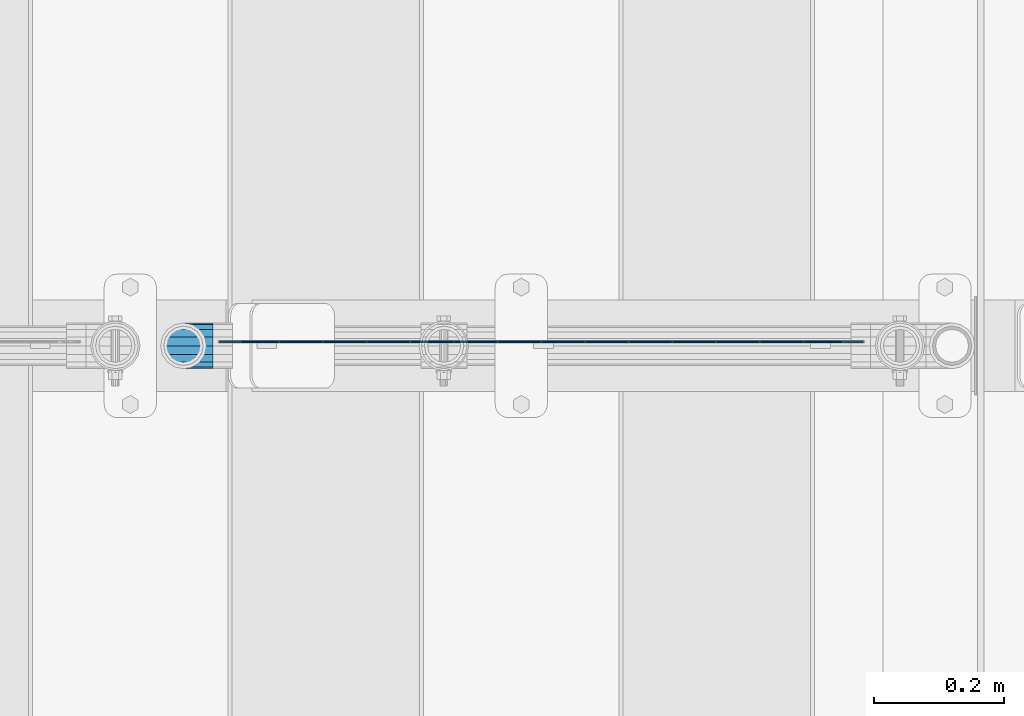
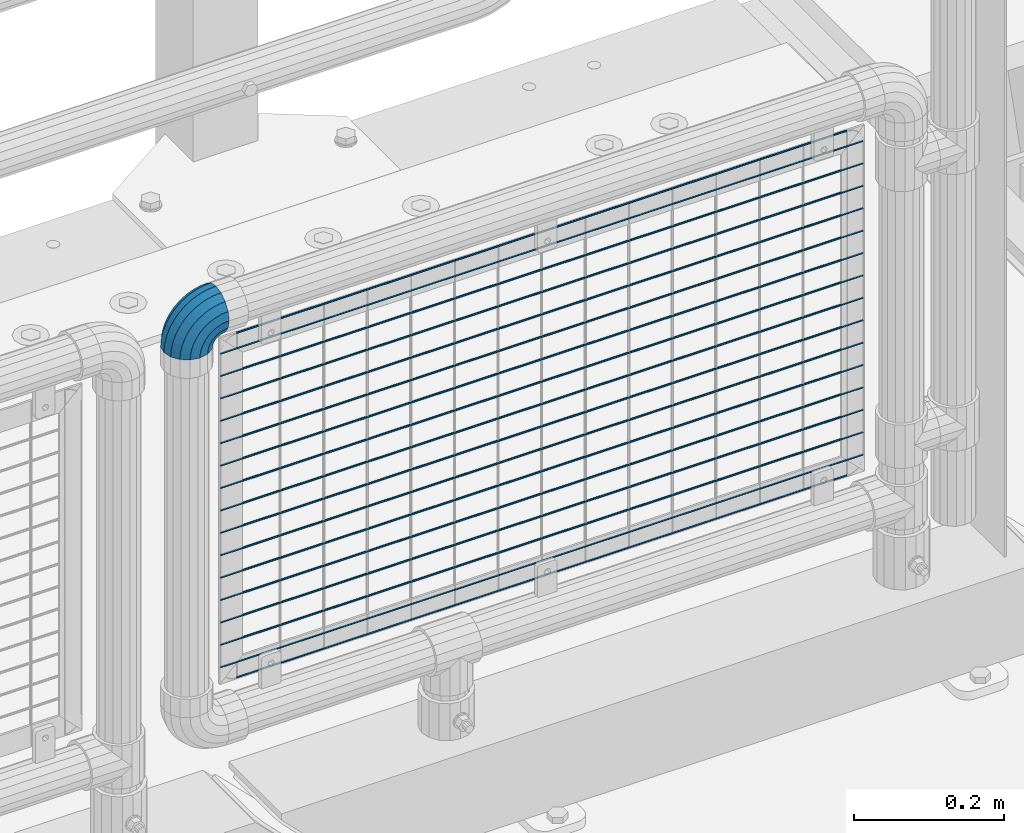
# One storey, part 147 of 219: 17 beams, 1 member.
"""IFC2X3 building model written with IfcOpenShell, lengths in millimetres."""

from ifc_helpers import new_model, si_unit, frame, origin_with_axes, place, context, subcontext, project, spatial, faceted_brep, material, type_object, element, save


model = new_model("IFC2X3")

# Units and contexts
model_context = context("Model", 3, precision=1e-05, world=origin_with_axes())
body_context = subcontext(model_context, "Body", "Model", "MODEL_VIEW")
ifc_project = project(units=[si_unit("LENGTHUNIT", "METRE", prefix="MILLI"), si_unit("AREAUNIT", "SQUARE_METRE"), si_unit("VOLUMEUNIT", "CUBIC_METRE"), si_unit("MASSUNIT", "GRAM", prefix="KILO"), si_unit("TIMEUNIT", "SECOND"), si_unit("PLANEANGLEUNIT", "RADIAN"), si_unit("SOLIDANGLEUNIT", "STERADIAN"), si_unit("THERMODYNAMICTEMPERATUREUNIT", "DEGREE_CELSIUS"), si_unit("LUMINOUSINTENSITYUNIT", "LUMEN")], contexts=[model_context])

# Site, building, storey
site_placement = place(None, origin_with_axes())
site = spatial("IfcSite", under=ifc_project, at=site_placement, CompositionType="ELEMENT")
building_placement = place(site_placement, origin_with_axes())
building = spatial("IfcBuilding", under=site, at=building_placement, Name="Standard", CompositionType="ELEMENT")
storey_placement = place(building_placement, origin_with_axes())
storey = spatial("IfcBuildingStorey", under=building, at=storey_placement, Name="Undefined", CompositionType="ELEMENT", Elevation=0.0)

# Beams
ifc_material = material(Name="Misc_Undefined")
beam_type = type_object("IfcBeamType", Name="D3", PredefinedType="NOTDEFINED")
for number, where, z_axis, x_axis in (
    (1, (12386.61, 31670.4999883346, 633.023), (0.0, 0.0, 1.0), (1.0, 0.0, 0.0)),
    (2, (12386.61, 31670.4999883385, 815.168), (0.0, 0.0, 1.0), (1.0, 0.0, 0.0)),
    (3, (12386.61, 31670.4999883354, 669.452), (0.0, 0.0, 1.0), (1.0, 0.0, 0.0)),
    (4, (12386.61, 31670.4999883338, 596.594000000001), (0.0, 0.0, 1.0), (1.0, 0.0, 0.0)),
    (5, (12386.61, 31670.4999883331, 560.165), (0.0, 0.0, 1.0), (1.0, 0.0, 0.0)),
    (6, (12386.61, 31670.4999883377, 778.739), (0.0, 0.0, 1.0), (1.0, 0.0, 0.0)),
    (7, (12386.61, 31670.4999883323, 523.736), (0.0, 0.0, 1.0), (1.0, 0.0, 0.0)),
    (8, (12386.61, 31670.4999883392, 851.597), (0.0, 0.0, 1.0), (1.0, 0.0, 0.0)),
    (9, (12386.61, 31670.4999883315, 487.307), (0.0, 0.0, 1.0), (1.0, 0.0, 0.0)),
    (10, (12386.61, 31670.4999883361, 705.881), (0.0, 0.0, 1.0), (1.0, 0.0, 0.0)),
    (11, (12386.61, 31670.4999883308, 450.878), (0.0, 0.0, 1.0), (1.0, 0.0, 0.0)),
    (12, (12386.61, 31670.49998834, 888.026), (0.0, 0.0, 1.0), (1.0, 0.0, 0.0)),
    (13, (12386.61, 31670.4999883369, 742.31), (0.0, 0.0, 1.0), (1.0, 0.0, 0.0)),
    (14, (12386.61, 31670.49998833, 414.449), (0.0, 0.0, 1.0), (1.0, 0.0, 0.0)),
):
    element("IfcBeam", number, at=place(storey_placement, frame(where, z_axis=z_axis, x_axis=x_axis)), inside=storey, type_object=beam_type, material=ifc_material, ObjectType="D3", context=body_context, shape_type="Brep", body=[
        faceted_brep([(0.0, -1.5, -5.6843418860808e-14), (0.0, -0.75, -1.29903810567669), (988.390000000285, -0.75, -1.29903810567669), (988.390000000285, -1.5, 0.0), (0.0, 0.75, -1.29903810567669), (988.390000000285, 0.75, -1.29903810567669), (0.0, 1.5, -5.6843418860808e-14), (988.390000000285, 1.5, 0.0), (0.0, 0.75, 1.29903810567669), (988.390000000285, 0.75, 1.29903810567669), (0.0, -0.75, 1.29903810567669), (988.390000000285, -0.75, 1.29903810567669)], [[[0, 1, 2, 3]], [[1, 4, 5, 2]], [[4, 6, 7, 5]], [[6, 8, 9, 7]], [[8, 10, 11, 9]], [[10, 0, 3, 11]], [[5, 7, 9, 11, 3, 2]], [[10, 8, 6, 4, 1, 0]]]),
    ])
beam_1_placement = place(storey_placement, frame((12411.61, 31670.4999830243, 353.02), z_axis=(0.0, 0.0, 1.0), x_axis=(1.0, 0.0, 0.0)))
element("IfcBeam", 15, at=beam_1_placement, inside=storey, type_object=beam_type, material=ifc_material, ObjectType="D3", context=body_context, shape_type="Brep", body=[
    faceted_brep([(0.0, -1.5, -5.6843418860808e-14), (0.0, -0.75, -1.29903810567669), (938.390000000134, -0.749999999992724, -1.29903810567669), (938.390000000136, -1.49999999999272, 0.0), (0.0, 0.75, -1.29903810567669), (938.390000000134, 0.750000000007276, -1.29903810567663), (0.0, 1.5, -5.6843418860808e-14), (938.390000000134, 1.50000000000728, 0.0), (0.0, 0.75, 1.29903810567669), (938.390000000134, 0.750000000007276, 1.29903810567669), (0.0, -0.75, 1.29903810567669), (938.390000000134, -0.749999999992724, 1.29903810567669)], [[[0, 1, 2, 3]], [[1, 4, 5, 2]], [[4, 6, 7, 5]], [[6, 8, 9, 7]], [[8, 10, 11, 9]], [[10, 0, 3, 11]], [[5, 7, 9, 11, 3, 2]], [[10, 8, 6, 4, 1, 0]]]),
])
beam_2_placement = place(storey_placement, frame((12386.61, 31670.4999883292, 378.02), z_axis=(0.0, 0.0, 1.0), x_axis=(1.0, 0.0, 0.0)))
element("IfcBeam", 16, at=beam_2_placement, inside=storey, type_object=beam_type, material=ifc_material, ObjectType="D3", context=body_context, shape_type="Brep", body=[
    faceted_brep([(0.0, -1.5, -5.6843418860808e-14), (0.0, -0.75, -1.29903810567669), (988.390000000285, -0.75, -1.29903810567669), (988.390000000285, -1.5, 0.0), (0.0, 0.75, -1.29903810567669), (988.390000000285, 0.75, -1.29903810567669), (0.0, 1.5, -5.6843418860808e-14), (988.390000000285, 1.5, 0.0), (0.0, 0.75, 1.29903810567669), (988.390000000285, 0.75, 1.29903810567669), (0.0, -0.75, 1.29903810567669), (988.390000000285, -0.75, 1.29903810567669)], [[[0, 1, 2, 3]], [[1, 4, 5, 2]], [[4, 6, 7, 5]], [[6, 8, 9, 7]], [[8, 10, 11, 9]], [[10, 0, 3, 11]], [[5, 7, 9, 11, 3, 2]], [[10, 8, 6, 4, 1, 0]]]),
])
beam_3_placement = place(storey_placement, frame((12411.61, 31670.49998304, 913.02), z_axis=(0.0, 0.0, 1.0), x_axis=(1.0, 0.0, 0.0)))
element("IfcBeam", 17, at=beam_3_placement, inside=storey, type_object=beam_type, material=ifc_material, ObjectType="D3", context=body_context, shape_type="Brep", body=[
    faceted_brep([(0.0, -1.5, -5.6843418860808e-14), (0.0, -0.75, -1.29903810567669), (938.390000000134, -0.749999999992724, -1.29903810567669), (938.390000000136, -1.49999999999272, 0.0), (0.0, 0.75, -1.29903810567669), (938.390000000134, 0.750000000007276, -1.29903810567663), (0.0, 1.5, -5.6843418860808e-14), (938.390000000134, 1.50000000000728, 0.0), (0.0, 0.75, 1.29903810567669), (938.390000000134, 0.750000000007276, 1.29903810567669), (0.0, -0.75, 1.29903810567669), (938.390000000134, -0.749999999992724, 1.29903810567669)], [[[0, 1, 2, 3]], [[1, 4, 5, 2]], [[4, 6, 7, 5]], [[6, 8, 9, 7]], [[8, 10, 11, 9]], [[10, 0, 3, 11]], [[5, 7, 9, 11, 3, 2]], [[10, 8, 6, 4, 1, 0]]]),
])

# Member
member_type = type_object("IfcMemberType", PredefinedType="NOTDEFINED")
member_placement = place(storey_placement, frame((12331.61, 31664.5, 924.849999999999), z_axis=(-0.707106781186548, 0.0, 0.707106781186548), x_axis=(0.707106781186548, 0.0, 0.707106781186547)))
element("IfcMember", 18, at=member_placement, inside=storey, type_object=member_type, material=ifc_material, context=body_context, shape_type="Brep", body=[
    faceted_brep([(0.0, -35.1500000000015, 0.0), (9.51152146006825, -32.4743655677703, -9.51152146006643), (13.2759578763371, -32.4743655677703, -6.29638902527404), (5.36946880023152, -35.1500000000015, 4.58595959348168), (17.5749999999971, -24.8548033587067, -17.5749999999971), (19.978755663109, -24.8548033587067, -15.5219987155597), (22.9628441077002, -13.4513226476338, -22.9628441077002), (24.4574219585238, -13.4513226476338, -21.686354032392), (24.8548033587049, 0.0, -24.8548033587031), (26.0301204183133, 0.0, -23.8509877587985), (22.9628441077002, 13.4513226476338, -22.9628441077002), (24.4574219585238, 13.4513226476338, -21.686354032392), (17.5749999999971, 24.8548033587067, -17.5749999999971), (19.978755663109, 24.8548033587067, -15.5219987155597), (9.51152146006825, 32.4743655677703, -9.51152146006643), (13.2759578763371, 32.4743655677703, -6.29638902527404), (0.0, 35.1500000000015, 0.0), (5.36946880023152, 35.1500000000015, 4.58595959348168), (-9.51152146007189, 32.4743655677703, 9.51152146007371), (-2.53702027587497, 32.4743655677703, 15.4683082122356), (-17.5750000000007, 24.8548033587067, 17.5750000000025), (-9.23981806264692, 24.8548033587067, 24.6939179025212), (-22.9628441077039, 13.4513226476338, 22.9628441077057), (-13.718484358059, 13.4513226476338, 30.8582732193536), (-24.8548033587085, 0.0, 24.8548033587103), (-15.2911828178485, 0.0, 33.02290694576), (-22.9628441077039, -13.4513226476338, 22.9628441077057), (-13.718484358059, -13.4513226476338, 30.8582732193536), (-17.5750000000007, -24.8548033587067, 17.5750000000025), (-9.23981806264692, -24.8548033587067, 24.6939179025212), (-9.51152146007189, -32.4743655677703, 9.51152146007371), (-2.53702027587497, -32.4743655677703, 15.4683082122356), (0.0, -30.3499999999985, 0.0), (-8.21265081971978, -28.0397438117179, 8.2126508197216), (-1.45732902223881, -28.0397438117179, 13.9822406910407), (5.36946880023152, -30.3499999999985, 4.58595959348168), (-15.1750000000011, -21.46069080901, 15.1750000000029), (-7.24480876131474, -21.46069080901, 21.9480231689977), (-19.8270929920018, -11.614442172282, 19.8270929920018), (-11.1118790903547, -11.614442172282, 27.2705888550809), (-21.4606908090136, 0.0, 21.4606908090154), (-12.4698136068446, 0.0, 29.1396253727617), (-19.8270929920018, 11.614442172282, 19.8270929920018), (-11.1118790903547, 11.614442172282, 27.2705888550809), (-15.1750000000011, 21.46069080901, 15.1750000000029), (-7.24480876131474, 21.46069080901, 21.9480231689977), (-8.21265081971978, 28.0397438117179, 8.2126508197216), (-1.45732902223881, 28.0397438117179, 13.9822406910407), (0.0, 30.3499999999985, 0.0), (5.36946880023152, 30.3499999999985, 4.58595959348168), (8.21265081971615, 28.0397438117179, -8.21265081971433), (12.1962666227028, 28.0397438117179, -4.81032150407918), (15.1749999999975, 21.46069080901, -15.1749999999975), (17.9837463617769, 21.46069080901, -12.7761039820361), (19.8270929919981, 11.614442172282, -19.8270929919963), (21.8508166908196, 11.614442172282, -18.0986696681193), (21.46069080901, 0.0, -21.4606908090082), (23.2087512073094, 0.0, -19.9677061858001), (19.8270929919981, -11.614442172282, -19.8270929919963), (21.8508166908196, -11.614442172282, -18.0986696681193), (15.1749999999975, -21.46069080901, -15.1749999999975), (17.9837463617769, -21.46069080901, -12.7761039820361), (8.21265081971615, -28.0397438117179, -8.21265081971433), (12.1962666227028, -28.0397438117179, -4.81032150407918), (17.4970053560701, -32.4743655677703, -3.70972780291777), (11.3902326651123, -35.1500000000015, 8.27548843508521), (22.6740772628609, -24.8548033587067, -13.870303514941), (26.1332861179508, -13.4513226476338, -20.6593831546797), (27.3479987309584, 0.0, -23.0433908901377), (26.1332861179508, 13.4513226476338, -20.6593831546797), (22.6740772628609, 24.8548033587067, -13.870303514941), (17.4970053560701, 32.4743655677703, -3.70972780291777), (11.3902326651123, 35.1500000000015, 8.27548843508521), (5.28345997415727, 32.4743655677703, 20.2607046730882), (0.106388067365515, 24.8548033587067, 30.4212803851115), (-3.35282078772343, 13.4513226476338, 37.2103600248465), (-4.56753340073192, 0.0, 39.5943677603063), (-3.35282078772343, -13.4513226476338, 37.2103600248465), (0.106388067365515, -24.8548033587067, 30.4212803851115), (5.28345997415727, -32.4743655677703, 20.2607046730882), (6.11738625912403, -28.0397438117179, 18.6240321853929), (11.3902326651123, -30.3499999999985, 8.27548843508521), (1.64728291997471, -21.46069080901, 27.3971039595035), (-1.33954464053568, -11.614442172282, 33.2590831078942), (-2.38837900198178, 0.0, 35.3175364442013), (-1.33954464053568, 11.614442172282, 33.2590831078942), (1.64728291997471, 21.46069080901, 27.3971039595035), (6.11738625912403, 28.0397438117179, 18.6240321853929), (11.3902326651123, 30.3499999999985, 8.27548843508521), (16.6630790711033, 28.0397438117179, -2.07305531522616), (21.1331824102526, 21.46069080901, -10.8461270893331), (24.1200099707648, 11.614442172282, -16.7081062377274), (25.1688443322091, 0.0, -18.7665595740327), (24.1200099707648, -11.614442172282, -16.7081062377274), (21.1331824102526, -21.46069080901, -10.8461270893331), (16.6630790711033, -28.0397438117179, -2.07305531522616), (22.0707277014599, -32.4743655677703, -1.81522997692991), (17.9140404065201, -35.1500000000015, 10.9777380798878), (25.5945970362091, -24.8548033587067, -12.6605846156435), (27.9491712485078, -13.4513226476338, -19.9072189058916), (28.7759877588005, 0.0, -22.4518984678853), (27.9491712485078, 13.4513226476338, -19.9072189058916), (25.5945970362091, 24.8548033587067, -12.6605846156435), (22.0707277014599, 32.4743655677703, -1.81522997692991), (17.9140404065201, 35.1500000000015, 10.9777380798878), (13.7573531115804, 32.4743655677703, 23.7707061367109), (10.2334837768312, 24.8548033587067, 34.6160607754227), (7.8789095645343, 13.4513226476338, 41.8626950656708), (7.0520930542416, 0.0, 44.4073746276645), (7.8789095645343, -13.4513226476338, 41.8626950656708), (10.2334837768312, -24.8548033587067, 34.6160607754227), (13.7573531115804, -32.4743655677703, 23.7707061367109), (14.3249803951003, -28.0397438117179, 22.023728990971), (17.9140404065201, -30.3499999999985, 10.9777380798878), (11.28232223551, -21.46069080901, 31.3880679179965), (9.24928305077992, -11.614442172282, 37.6451191472715), (8.53537462724125, 0.0, 39.8423033494473), (9.24928305077992, 11.614442172282, 37.6451191472715), (11.28232223551, 21.46069080901, 31.3880679179965), (14.3249803951003, 28.0397438117179, 22.023728990971), (17.9140404065201, 30.3499999999985, 10.9777380798878), (21.5031004179409, 28.0397438117179, -0.0682528311899659), (24.5457585775303, 21.46069080901, -9.43259175821731), (26.5787977622622, 11.614442172282, -15.6896429874923), (27.2927061857999, 0.0, -17.8868271896681), (26.5787977622622, -11.614442172282, -15.6896429874923), (24.5457585775303, -21.46069080901, -9.43259175821731), (21.5031004179409, -28.0397438117179, -0.0682528311899659), (26.8845046890492, -32.4743655677703, -0.659544371261291), (24.7802542265817, -35.1500000000015, 12.6261701733893), (28.6684020936827, -24.8548033587067, -11.9226293117899), (29.8603642316984, -13.4513226476338, -19.4483820661226), (30.2789256727474, 0.0, -22.0910749985305), (29.8603642316984, 13.4513226476338, -19.4483820661226), (28.6684020936827, 24.8548033587067, -11.9226293117899), (26.8845046890492, 32.4743655677703, -0.659544371261291), (24.7802542265817, 35.1500000000015, 12.6261701733893), (22.676003764117, 32.4743655677703, 25.9118847180398), (20.8921063594835, 24.8548033587067, 37.1749696585684), (19.7001442214678, 13.4513226476338, 44.7007224129011), (19.2815827804179, 0.0, 47.343415345309), (19.7001442214678, -13.4513226476338, 44.7007224129011), (20.8921063594835, -24.8548033587067, 37.1749696585684), (22.676003764117, -32.4743655677703, 25.9118847180398), (22.963355178621, -28.0397438117179, 24.0976192894668), (24.7802542265817, -30.3499999999985, 12.6261701733893), (21.4230625404825, -21.46069080901, 33.8226442665673), (20.3938719035323, -11.614442172282, 40.3206982094962), (20.032468212612, 0.0, 42.6025113104515), (20.3938719035323, 11.614442172282, 40.3206982094962), (21.4230625404825, 21.46069080901, 33.8226442665673), (22.963355178621, 28.0397438117179, 24.0976192894668), (24.7802542265817, 30.3499999999985, 12.6261701733893), (26.5971532745452, 28.0397438117179, 1.15472105731169), (28.1374459126837, 21.46069080901, -8.57030391978697), (29.1666365496339, 11.614442172282, -15.0683578627177), (29.5280402405542, 0.0, -17.350170963673), (29.1666365496339, -11.614442172282, -15.0683578627177), (28.1374459126837, -21.46069080901, -8.57030391978697), (26.5971532745434, -28.0397438117179, 1.15472105731169), (31.8198051533936, -32.4743655677703, -0.271127801024704), (31.8198051533927, -35.1500000000015, 13.1801948466091), (31.8198051533927, -24.8548033587067, -11.6746085121013), (31.8198051533927, -13.4513226476338, -19.2941707211648), (31.8198051533918, 0.0, -21.9698051533924), (31.8198051533927, 13.4513226476338, -19.2941707211648), (31.8198051533927, 24.8548033587067, -11.6746085121013), (31.8198051533936, 32.4743655677703, -0.271127801024704), (31.8198051533927, 35.1500000000015, 13.1801948466091), (31.8198051533927, 32.4743655677703, 26.6315174942411), (31.8198051533936, 24.8548033587067, 38.0349982053158), (31.8198051533936, 13.4513226476338, 45.6545604143794), (31.8198051533946, 0.0, 48.3301948466069), (31.8198051533936, -13.4513226476338, 45.6545604143794), (31.8198051533936, -24.8548033587067, 38.0349982053158), (31.8198051533927, -32.4743655677703, 26.6315174942411), (31.8198051533946, -28.0397438117179, 24.7946370188874), (31.8198051533927, -30.3499999999985, 13.1801948466091), (31.8198051533936, -21.46069080901, 34.6408856556191), (31.8198051533927, -11.614442172282, 41.219938658327), (31.8198051533936, 0.0, 43.5301948466076), (31.8198051533927, 11.614442172282, 41.219938658327), (31.8198051533936, 21.46069080901, 34.6408856556191), (31.8198051533946, 28.0397438117179, 24.7946370188874), (31.8198051533927, 30.3499999999985, 13.1801948466091), (31.8198051533918, 28.0397438117179, 1.56575267432709), (31.8198051533918, 21.46069080901, -8.28049596240453), (31.8198051533936, 11.614442172282, -14.8595489651088), (31.8198051533946, 0.0, -17.1698051533931), (31.8198051533936, -11.614442172282, -14.8595489651088), (31.8198051533918, -21.46069080901, -8.28049596240453), (31.8198051533918, -28.0397438117179, 1.56575267432709), (36.755105617739, -32.4743655677703, -0.659544371261291), (38.8593560802037, -35.1500000000015, 12.6261701733893), (34.9712082131036, -24.8548033587067, -11.9226293117918), (33.7792460750888, -13.4513226476338, -19.4483820661226), (33.3606846340399, 0.0, -22.0910749985305), (33.7792460750888, 13.4513226476338, -19.4483820661226), (34.9712082131036, 24.8548033587067, -11.9226293117918), (36.755105617739, 32.4743655677703, -0.659544371261291), (38.8593560802037, 35.1500000000015, 12.6261701733893), (40.9636065426703, 32.4743655677703, 25.9118847180398), (42.7475039473029, 24.8548033587067, 37.1749696585703), (43.9394660853186, 13.4513226476338, 44.7007224129029), (44.3580275263666, 0.0, 47.3434153453072), (43.9394660853186, -13.4513226476338, 44.7007224129029), (42.7475039473029, -24.8548033587067, 37.1749696585703), (40.9636065426703, -32.4743655677703, 25.9118847180398), (40.6762551281663, -28.0397438117179, 24.0976192894668), (38.8593560802037, -30.3499999999985, 12.6261701733893), (42.2165477663048, -21.46069080901, 33.8226442665673), (43.2457384032541, -11.614442172282, 40.3206982094962), (43.6071420941744, 0.0, 42.6025113104515), (43.2457384032541, 11.614442172282, 40.3206982094962), (42.2165477663048, 21.46069080901, 33.8226442665673), (40.6762551281663, 28.0397438117179, 24.0976192894668), (38.8593560802037, 30.3499999999985, 12.6261701733893), (37.0424570322421, 28.0397438117179, 1.15472105731169), (35.5021643941018, 21.46069080901, -8.57030391978878), (34.4729737571524, 11.614442172282, -15.0683578627177), (34.1115700662331, 0.0, -17.350170963673), (34.4729737571524, -11.614442172282, -15.0683578627177), (35.5021643941018, -21.46069080901, -8.57030391978878), (37.0424570322421, -28.0397438117179, 1.15472105731169), (41.5688826053274, -32.4743655677703, -1.81522997692991), (45.7255699002653, -35.1500000000015, 10.9777380798914), (38.0450132705764, -24.8548033587067, -12.6605846156435), (35.6904390582804, -13.4513226476338, -19.9072189058897), (34.8636225479868, 0.0, -22.4518984678853), (35.6904390582804, 13.4513226476338, -19.9072189058897), (38.0450132705764, 24.8548033587067, -12.6605846156435), (41.5688826053274, 32.4743655677703, -1.81522997692991), (45.7255699002653, 35.1500000000015, 10.9777380798914), (49.882257195206, 32.4743655677703, 23.7707061367091), (53.4061265299524, 24.8548033587067, 34.6160607754227), (55.7607007422521, 13.4513226476338, 41.8626950656708), (56.5875172525457, 0.0, 44.4073746276645), (55.7607007422521, -13.4513226476338, 41.8626950656708), (53.4061265299524, -24.8548033587067, 34.6160607754227), (49.882257195206, -32.4743655677703, 23.7707061367091), (49.314629911687, -28.0397438117179, 22.0237289909692), (45.7255699002653, -30.3499999999985, 10.9777380798914), (52.3572880712773, -21.46069080901, 31.3880679179965), (54.3903272560065, -11.614442172282, 37.6451191472715), (55.1042356795451, 0.0, 39.8423033494491), (54.3903272560065, 11.614442172282, 37.6451191472715), (52.3572880712773, 21.46069080901, 31.3880679179965), (49.314629911687, 28.0397438117179, 22.0237289909692), (45.7255699002653, 30.3499999999985, 10.9777380798914), (42.1365098888464, 28.0397438117179, -0.0682528311899659), (39.0938517292561, 21.46069080901, -9.43259175821731), (37.0608125445251, 11.614442172282, -15.6896429874923), (36.3469041209864, 0.0, -17.8868271896699), (37.0608125445251, -11.614442172282, -15.6896429874923), (39.0938517292561, -21.46069080901, -9.43259175821731), (42.1365098888464, -28.0397438117179, -0.0682528311899659), (46.1426049507154, -32.4743655677703, -3.70972780291777), (52.2493776416723, -35.1500000000015, 8.27548843508339), (40.9655330439255, -24.8548033587067, -13.8703035149429), (37.5063241888365, -13.4513226476338, -20.6593831546797), (36.2916115758289, 0.0, -23.0433908901377), (37.5063241888365, 13.4513226476338, -20.6593831546797), (40.9655330439255, 24.8548033587067, -13.8703035149429), (46.1426049507154, 32.4743655677703, -3.70972780291777), (52.2493776416723, 35.1500000000015, 8.27548843508339), (58.35615033263, 32.4743655677703, 20.2607046730882), (63.5332222394209, 24.8548033587067, 30.4212803851115), (66.9924310945089, 13.4513226476338, 37.2103600248465), (68.2071437075174, 0.0, 39.5943677603045), (66.9924310945089, -13.4513226476338, 37.2103600248465), (63.5332222394209, -24.8548033587067, 30.4212803851115), (58.35615033263, -32.4743655677703, 20.2607046730882), (57.5222240476614, -28.0397438117179, 18.6240321853948), (52.2493776416723, -30.3499999999985, 8.27548843508339), (61.9923273868126, -21.46069080901, 27.3971039595035), (64.9791549473239, -11.614442172282, 33.2590831078942), (66.0279893087691, 0.0, 35.3175364442013), (64.9791549473239, 11.614442172282, 33.2590831078942), (61.9923273868126, 21.46069080901, 27.3971039595035), (57.5222240476614, 28.0397438117179, 18.6240321853948), (52.2493776416723, 30.3499999999985, 8.27548843508339), (46.976531235684, 28.0397438117179, -2.07305531522616), (42.5064278965338, 21.46069080901, -10.8461270893331), (39.5196003360215, 11.614442172282, -16.7081062377274), (38.4707659745773, 0.0, -18.7665595740309), (39.5196003360215, -11.614442172282, -16.7081062377274), (42.5064278965338, -21.46069080901, -10.8461270893331), (46.976531235684, -28.0397438117179, -2.07305531522616), (50.3636524304493, -32.4743655677703, -6.29638902527586), (58.2701415065549, -35.1500000000015, 4.58595959347986), (43.6608546436764, -24.8548033587067, -15.5219987155615), (39.1821883482644, -13.4513226476338, -21.686354032392), (37.6094898884739, 0.0, -23.8509877587985), (39.1821883482644, 13.4513226476338, -21.686354032392), (43.6608546436764, 24.8548033587067, -15.5219987155615), (50.3636524304493, 32.4743655677703, -6.29638902527586), (58.2701415065549, 35.1500000000015, 4.58595959347986), (66.1766305826604, 32.4743655677703, 15.4683082122374), (72.8794283694315, 24.8548033587067, 24.6939179025212), (77.3580946648453, 13.4513226476338, 30.8582732193536), (78.9307931246358, 0.0, 33.02290694576), (77.3580946648453, -13.4513226476338, 30.8582732193536), (72.8794283694315, -24.8548033587067, 24.6939179025212), (66.1766305826604, -32.4743655677703, 15.4683082122374), (65.0969393290261, -28.0397438117179, 13.9822406910407), (58.2701415065549, -30.3499999999985, 4.58595959347986), (70.8844190681011, -21.46069080901, 21.9480231689959), (74.7514893971411, -11.614442172282, 27.2705888550809), (76.109423913631, 0.0, 29.139625372758), (74.7514893971411, 11.614442172282, 27.2705888550809), (70.8844190681011, 21.46069080901, 21.9480231689959), (65.0969393290261, 28.0397438117179, 13.9822406910407), (58.2701415065549, 30.3499999999985, 4.58595959347986), (51.4433436840836, 28.0397438117179, -4.810321504081), (45.6558639450086, 21.46069080901, -12.7761039820361), (41.7887936159668, 11.614442172282, -18.0986696681193), (40.4308590994788, 0.0, -19.9677061858001), (41.7887936159668, -11.614442172282, -18.0986696681193), (45.6558639450086, -21.46069080901, -12.7761039820361), (51.4433436840836, -28.0397438117179, -4.810321504081), (54.1280888467181, -32.4743655677703, -9.51152146006643), (63.6396103067882, -35.1500000000015, 3.63797880709171e-12), (46.0646103067875, -24.8548033587067, -17.5749999999971), (40.6767661990853, -13.4513226476338, -22.9628441077002), (38.7848069480806, 0.0, -24.8548033587049), (40.6767661990853, 13.4513226476338, -22.9628441077002), (46.0646103067875, 24.8548033587067, -17.5749999999971), (54.1280888467181, 32.4743655677703, -9.51152146006643), (63.6396103067882, 35.1500000000015, 3.63797880709171e-12), (73.1511317668574, 32.4743655677703, 9.51152146007189), (81.214610306788, 24.8548033587067, 17.5750000000025), (86.6024544144902, 13.4513226476338, 22.9628441077057), (88.4944136654949, 0.0, 24.8548033587103), (86.6024544144902, -13.4513226476338, 22.9628441077057), (81.214610306788, -24.8548033587067, 17.5750000000025), (73.1511317668574, -32.4743655677703, 9.51152146007189), (71.8522611265062, -28.0397438117179, 8.2126508197216), (63.6396103067882, -30.3499999999985, 3.63797880709171e-12), (78.8146103067875, -21.46069080901, 15.1750000000029), (83.4667032987863, -11.614442172282, 19.8270929920018), (85.1003011158, 0.0, 21.4606908090154), (83.4667032987863, 11.614442172282, 19.8270929920018), (78.8146103067875, 21.46069080901, 15.1750000000029), (71.8522611265062, 28.0397438117179, 8.2126508197216), (63.6396103067882, 30.3499999999985, 3.63797880709171e-12), (55.4269594870693, 28.0397438117179, -8.21265081971615), (48.464610306788, 21.46069080901, -15.1749999999975), (43.8125173147882, 11.614442172282, -19.8270929919963), (42.1789194977764, 0.0, -21.4606908090082), (43.8125173147882, -11.614442172282, -19.8270929919963), (48.464610306788, -21.46069080901, -15.1749999999975), (55.4269594870693, -28.0397438117179, -8.21265081971615)], [[[0, 1, 2, 3]], [[1, 4, 5, 2]], [[4, 6, 7, 5]], [[6, 8, 9, 7]], [[8, 10, 11, 9]], [[10, 12, 13, 11]], [[12, 14, 15, 13]], [[14, 16, 17, 15]], [[16, 18, 19, 17]], [[18, 20, 21, 19]], [[20, 22, 23, 21]], [[22, 24, 25, 23]], [[24, 26, 27, 25]], [[26, 28, 29, 27]], [[28, 30, 31, 29]], [[30, 0, 3, 31]], [[32, 33, 34, 35]], [[33, 36, 37, 34]], [[36, 38, 39, 37]], [[38, 40, 41, 39]], [[40, 42, 43, 41]], [[42, 44, 45, 43]], [[44, 46, 47, 45]], [[46, 48, 49, 47]], [[48, 50, 51, 49]], [[50, 52, 53, 51]], [[52, 54, 55, 53]], [[54, 56, 57, 55]], [[56, 58, 59, 57]], [[58, 60, 61, 59]], [[60, 62, 63, 61]], [[62, 32, 35, 63]], [[30, 28, 26, 24, 22, 20, 18, 16, 14, 12, 10, 8, 6, 4, 1, 0], [62, 60, 58, 56, 54, 52, 50, 48, 46, 44, 42, 40, 38, 36, 33, 32]], [[3, 2, 64, 65]], [[2, 5, 66, 64]], [[5, 7, 67, 66]], [[7, 9, 68, 67]], [[9, 11, 69, 68]], [[11, 13, 70, 69]], [[13, 15, 71, 70]], [[15, 17, 72, 71]], [[17, 19, 73, 72]], [[19, 21, 74, 73]], [[21, 23, 75, 74]], [[23, 25, 76, 75]], [[25, 27, 77, 76]], [[27, 29, 78, 77]], [[29, 31, 79, 78]], [[31, 3, 65, 79]], [[35, 34, 80, 81]], [[34, 37, 82, 80]], [[37, 39, 83, 82]], [[39, 41, 84, 83]], [[41, 43, 85, 84]], [[43, 45, 86, 85]], [[45, 47, 87, 86]], [[47, 49, 88, 87]], [[49, 51, 89, 88]], [[51, 53, 90, 89]], [[53, 55, 91, 90]], [[55, 57, 92, 91]], [[57, 59, 93, 92]], [[59, 61, 94, 93]], [[61, 63, 95, 94]], [[63, 35, 81, 95]], [[65, 64, 96, 97]], [[64, 66, 98, 96]], [[66, 67, 99, 98]], [[67, 68, 100, 99]], [[68, 69, 101, 100]], [[69, 70, 102, 101]], [[70, 71, 103, 102]], [[71, 72, 104, 103]], [[72, 73, 105, 104]], [[73, 74, 106, 105]], [[74, 75, 107, 106]], [[75, 76, 108, 107]], [[76, 77, 109, 108]], [[77, 78, 110, 109]], [[78, 79, 111, 110]], [[79, 65, 97, 111]], [[81, 80, 112, 113]], [[80, 82, 114, 112]], [[82, 83, 115, 114]], [[83, 84, 116, 115]], [[84, 85, 117, 116]], [[85, 86, 118, 117]], [[86, 87, 119, 118]], [[87, 88, 120, 119]], [[88, 89, 121, 120]], [[89, 90, 122, 121]], [[90, 91, 123, 122]], [[91, 92, 124, 123]], [[92, 93, 125, 124]], [[93, 94, 126, 125]], [[94, 95, 127, 126]], [[95, 81, 113, 127]], [[97, 96, 128, 129]], [[96, 98, 130, 128]], [[98, 99, 131, 130]], [[99, 100, 132, 131]], [[100, 101, 133, 132]], [[101, 102, 134, 133]], [[102, 103, 135, 134]], [[103, 104, 136, 135]], [[104, 105, 137, 136]], [[105, 106, 138, 137]], [[106, 107, 139, 138]], [[107, 108, 140, 139]], [[108, 109, 141, 140]], [[109, 110, 142, 141]], [[110, 111, 143, 142]], [[111, 97, 129, 143]], [[113, 112, 144, 145]], [[112, 114, 146, 144]], [[114, 115, 147, 146]], [[115, 116, 148, 147]], [[116, 117, 149, 148]], [[117, 118, 150, 149]], [[118, 119, 151, 150]], [[119, 120, 152, 151]], [[120, 121, 153, 152]], [[121, 122, 154, 153]], [[122, 123, 155, 154]], [[123, 124, 156, 155]], [[124, 125, 157, 156]], [[125, 126, 158, 157]], [[126, 127, 159, 158]], [[127, 113, 145, 159]], [[129, 128, 160, 161]], [[128, 130, 162, 160]], [[130, 131, 163, 162]], [[131, 132, 164, 163]], [[132, 133, 165, 164]], [[133, 134, 166, 165]], [[134, 135, 167, 166]], [[135, 136, 168, 167]], [[136, 137, 169, 168]], [[137, 138, 170, 169]], [[138, 139, 171, 170]], [[139, 140, 172, 171]], [[140, 141, 173, 172]], [[141, 142, 174, 173]], [[142, 143, 175, 174]], [[143, 129, 161, 175]], [[145, 144, 176, 177]], [[144, 146, 178, 176]], [[146, 147, 179, 178]], [[147, 148, 180, 179]], [[148, 149, 181, 180]], [[149, 150, 182, 181]], [[150, 151, 183, 182]], [[151, 152, 184, 183]], [[152, 153, 185, 184]], [[153, 154, 186, 185]], [[154, 155, 187, 186]], [[155, 156, 188, 187]], [[156, 157, 189, 188]], [[157, 158, 190, 189]], [[158, 159, 191, 190]], [[159, 145, 177, 191]], [[161, 160, 192, 193]], [[160, 162, 194, 192]], [[162, 163, 195, 194]], [[163, 164, 196, 195]], [[164, 165, 197, 196]], [[165, 166, 198, 197]], [[166, 167, 199, 198]], [[167, 168, 200, 199]], [[168, 169, 201, 200]], [[169, 170, 202, 201]], [[170, 171, 203, 202]], [[171, 172, 204, 203]], [[172, 173, 205, 204]], [[173, 174, 206, 205]], [[174, 175, 207, 206]], [[175, 161, 193, 207]], [[177, 176, 208, 209]], [[176, 178, 210, 208]], [[178, 179, 211, 210]], [[179, 180, 212, 211]], [[180, 181, 213, 212]], [[181, 182, 214, 213]], [[182, 183, 215, 214]], [[183, 184, 216, 215]], [[184, 185, 217, 216]], [[185, 186, 218, 217]], [[186, 187, 219, 218]], [[187, 188, 220, 219]], [[188, 189, 221, 220]], [[189, 190, 222, 221]], [[190, 191, 223, 222]], [[191, 177, 209, 223]], [[193, 192, 224, 225]], [[192, 194, 226, 224]], [[194, 195, 227, 226]], [[195, 196, 228, 227]], [[196, 197, 229, 228]], [[197, 198, 230, 229]], [[198, 199, 231, 230]], [[199, 200, 232, 231]], [[200, 201, 233, 232]], [[201, 202, 234, 233]], [[202, 203, 235, 234]], [[203, 204, 236, 235]], [[204, 205, 237, 236]], [[205, 206, 238, 237]], [[206, 207, 239, 238]], [[207, 193, 225, 239]], [[209, 208, 240, 241]], [[208, 210, 242, 240]], [[210, 211, 243, 242]], [[211, 212, 244, 243]], [[212, 213, 245, 244]], [[213, 214, 246, 245]], [[214, 215, 247, 246]], [[215, 216, 248, 247]], [[216, 217, 249, 248]], [[217, 218, 250, 249]], [[218, 219, 251, 250]], [[219, 220, 252, 251]], [[220, 221, 253, 252]], [[221, 222, 254, 253]], [[222, 223, 255, 254]], [[223, 209, 241, 255]], [[225, 224, 256, 257]], [[224, 226, 258, 256]], [[226, 227, 259, 258]], [[227, 228, 260, 259]], [[228, 229, 261, 260]], [[229, 230, 262, 261]], [[230, 231, 263, 262]], [[231, 232, 264, 263]], [[232, 233, 265, 264]], [[233, 234, 266, 265]], [[234, 235, 267, 266]], [[235, 236, 268, 267]], [[236, 237, 269, 268]], [[237, 238, 270, 269]], [[238, 239, 271, 270]], [[239, 225, 257, 271]], [[241, 240, 272, 273]], [[240, 242, 274, 272]], [[242, 243, 275, 274]], [[243, 244, 276, 275]], [[244, 245, 277, 276]], [[245, 246, 278, 277]], [[246, 247, 279, 278]], [[247, 248, 280, 279]], [[248, 249, 281, 280]], [[249, 250, 282, 281]], [[250, 251, 283, 282]], [[251, 252, 284, 283]], [[252, 253, 285, 284]], [[253, 254, 286, 285]], [[254, 255, 287, 286]], [[255, 241, 273, 287]], [[257, 256, 288, 289]], [[256, 258, 290, 288]], [[258, 259, 291, 290]], [[259, 260, 292, 291]], [[260, 261, 293, 292]], [[261, 262, 294, 293]], [[262, 263, 295, 294]], [[263, 264, 296, 295]], [[264, 265, 297, 296]], [[265, 266, 298, 297]], [[266, 267, 299, 298]], [[267, 268, 300, 299]], [[268, 269, 301, 300]], [[269, 270, 302, 301]], [[270, 271, 303, 302]], [[271, 257, 289, 303]], [[273, 272, 304, 305]], [[272, 274, 306, 304]], [[274, 275, 307, 306]], [[275, 276, 308, 307]], [[276, 277, 309, 308]], [[277, 278, 310, 309]], [[278, 279, 311, 310]], [[279, 280, 312, 311]], [[280, 281, 313, 312]], [[281, 282, 314, 313]], [[282, 283, 315, 314]], [[283, 284, 316, 315]], [[284, 285, 317, 316]], [[285, 286, 318, 317]], [[286, 287, 319, 318]], [[287, 273, 305, 319]], [[289, 288, 320, 321]], [[288, 290, 322, 320]], [[290, 291, 323, 322]], [[291, 292, 324, 323]], [[292, 293, 325, 324]], [[293, 294, 326, 325]], [[294, 295, 327, 326]], [[295, 296, 328, 327]], [[296, 297, 329, 328]], [[297, 298, 330, 329]], [[298, 299, 331, 330]], [[299, 300, 332, 331]], [[300, 301, 333, 332]], [[301, 302, 334, 333]], [[302, 303, 335, 334]], [[303, 289, 321, 335]], [[305, 304, 336, 337]], [[304, 306, 338, 336]], [[306, 307, 339, 338]], [[307, 308, 340, 339]], [[308, 309, 341, 340]], [[309, 310, 342, 341]], [[310, 311, 343, 342]], [[311, 312, 344, 343]], [[312, 313, 345, 344]], [[313, 314, 346, 345]], [[314, 315, 347, 346]], [[315, 316, 348, 347]], [[316, 317, 349, 348]], [[317, 318, 350, 349]], [[318, 319, 351, 350]], [[319, 305, 337, 351]], [[322, 323, 324, 325, 326, 327, 328, 329, 330, 331, 332, 333, 334, 335, 321, 320], [338, 339, 340, 341, 342, 343, 344, 345, 346, 347, 348, 349, 350, 351, 337, 336]]]),
])

save(model, "model.ifc")
